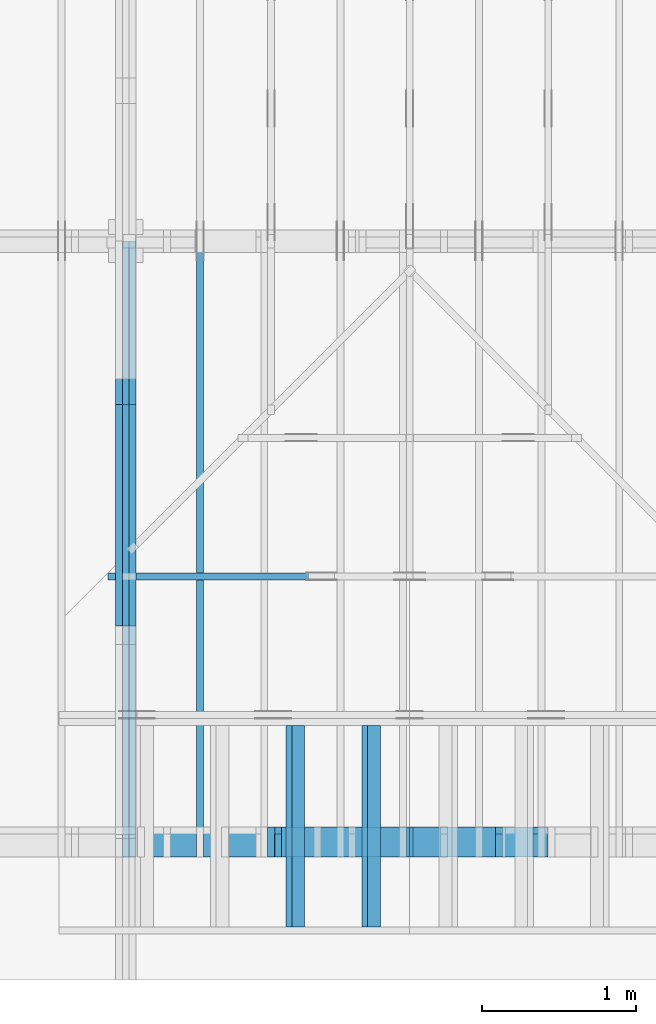
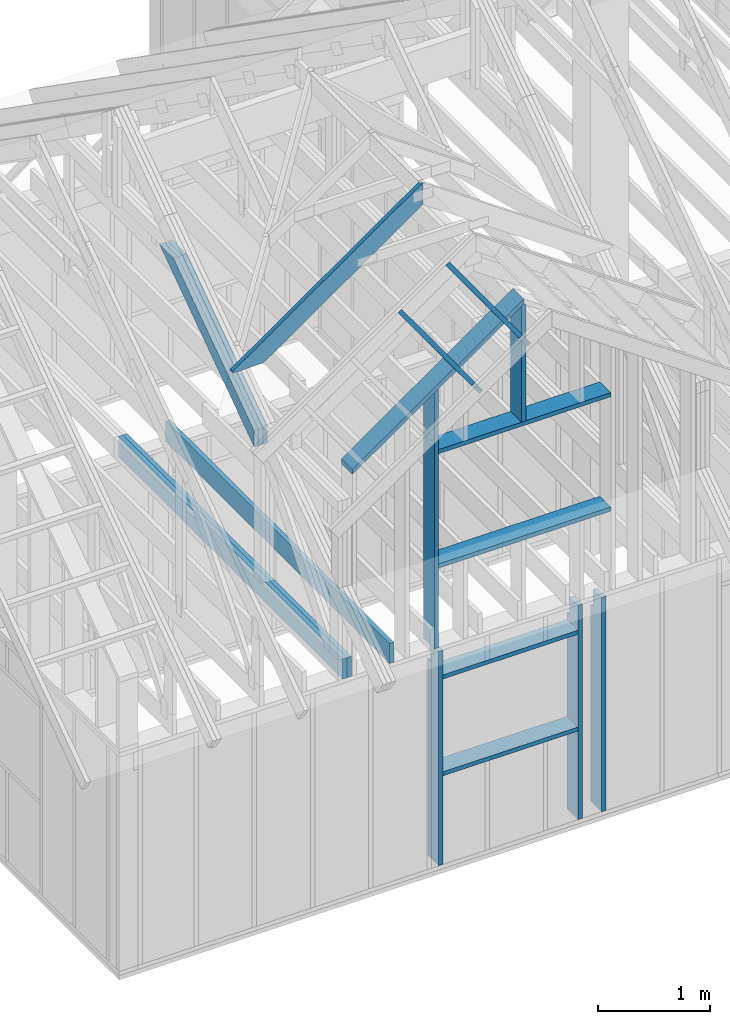
# One storey, part 6 of 70: 19 members, 6 elements without a shape of their own.
"""IFC2X3 building model written with IfcOpenShell, lengths in millimetres."""

from ifc_helpers import new_model, si_unit, frame, origin, origin_with_axes, origin_2d, place, context, project, spatial, faceted_brep, element, aggregate, save


model = new_model("IFC2X3")

# Units and contexts
model_context = context("Model", 3, precision=1e-05, world=origin())
plan_context = context("Plan", 2, precision=1e-05, world=origin_2d())
ifc_project = project(units=[si_unit("LENGTHUNIT", "METRE", prefix="MILLI"), si_unit("AREAUNIT", "SQUARE_METRE"), si_unit("VOLUMEUNIT", "CUBIC_METRE"), si_unit("SOLIDANGLEUNIT", "STERADIAN"), si_unit("PLANEANGLEUNIT", "RADIAN"), si_unit("MASSUNIT", "GRAM"), si_unit("TIMEUNIT", "SECOND"), si_unit("THERMODYNAMICTEMPERATUREUNIT", "DEGREE_CELSIUS"), si_unit("LUMINOUSINTENSITYUNIT", "LUMEN")], contexts=[model_context, plan_context])

# Site, building, storey
site_placement = place(None, origin_with_axes())
site = spatial("IfcSite", under=ifc_project, at=site_placement, CompositionType="ELEMENT")
building_placement = place(site_placement, origin_with_axes())
building = spatial("IfcBuilding", under=site, at=building_placement, Name="Layout 1", CompositionType="ELEMENT")
storey_placement = place(building_placement, origin_with_axes())
storey = spatial("IfcBuildingStorey", under=building, at=storey_placement, Name="Storey 1", CompositionType="ELEMENT", Elevation=0.0)

# Assembly, members
assembly_1_placement = place(storey_placement, frame((1969.9999999999982, 8000.000000000001, 1.1021457184401395e-14), z_axis=(-1.0, 1.836909530733566e-16, 6.123031769111886e-17), x_axis=(-1.836909530733566e-16, -1.0, 0.0)))
assembly_1 = element("IfcElementAssembly", 1, at=assembly_1_placement, inside=storey, Name="T11", AssemblyPlace="FACTORY", PredefinedType="TRUSS")
member_1_placement = place(assembly_1_placement, frame((7999.999999999999, 220.0, -135.0), z_axis=(0.0, 0.0, 1.0), x_axis=(-1.0, 1.2246063538223773e-16, 0.0)))
member_1 = element("IfcMember", 2, at=member_1_placement, Name="B3", context=model_context, shape_type="Brep", body=[
    faceted_brep([(3999.9999999999995, 220.00000000000054, 45.0), (0.0, 220.00000000000054, 45.0), (0.0, 0.0, 45.0), (3999.9999999999995, 0.0, 45.0), (0.0, 220.00000000000054, 0.0), (3999.9999999999995, 220.00000000000054, 4.898425415289508e-13), (3999.9999999999995, 0.0, 4.898425415289508e-13), (0.0, 0.0, 0.0), (0.0, 0.0, 0.0), (2.755364296100349e-15, -3.3742366240998092e-31, 45.0), (2.969670408019265e-14, 220.0, 45.0), (2.69413397840923e-14, 220.0, -1.6496267940043512e-30), (3999.9999999999995, -7.347638122934263e-13, 7.805495731188194e-29), (3999.9999999999995, -7.320084479973259e-13, 45.0), (5.061354936149714e-31, 2.755364296100349e-15, 45.0), (0.0, 0.0, 0.0), (3999.9999999999995, 220.00000000000054, 0.0), (3999.9999999999995, 220.00000000000054, 45.0), (3999.9999999999995, 5.400124791776761e-13, 45.0), (3999.9999999999995, 5.400124791776761e-13, 0.0), (0.0, 220.0, 0.0), (0.0, 220.0, 45.0), (3999.9999999999995, 220.00000000000065, 45.0), (3999.9999999999995, 220.00000000000065, 6.310887241768095e-30)], [[[0, 1, 2, 3]], [[4, 5, 6, 7]], [[8, 9, 10, 11]], [[12, 13, 14, 15]], [[16, 17, 18, 19]], [[20, 21, 22, 23]]]),
])
member_2_placement = place(assembly_1_placement, frame((7999.999999999999, 220.0, -180.0), z_axis=(0.0, 0.0, 1.0), x_axis=(-1.0, 1.2246063538223773e-16, 0.0)))
member_2 = element("IfcMember", 3, at=member_2_placement, Name="B3", context=model_context, shape_type="Brep", body=[
    faceted_brep([(3999.9999999999995, 220.00000000000054, 45.0), (0.0, 220.00000000000054, 45.0), (0.0, 0.0, 45.0), (3999.9999999999995, 0.0, 45.0), (0.0, 220.00000000000054, 0.0), (3999.9999999999995, 220.00000000000054, 4.898425415289508e-13), (3999.9999999999995, 0.0, 4.898425415289508e-13), (0.0, 0.0, 0.0), (0.0, 0.0, 0.0), (2.755364296100349e-15, -3.3742366240998092e-31, 45.0), (2.969670408019265e-14, 220.0, 45.0), (2.69413397840923e-14, 220.0, -1.6496267940043512e-30), (3999.9999999999995, -7.347638122934263e-13, 7.805495731188194e-29), (3999.9999999999995, -7.320084479973259e-13, 45.0), (5.061354936149714e-31, 2.755364296100349e-15, 45.0), (0.0, 0.0, 0.0), (3999.9999999999995, 220.00000000000054, 0.0), (3999.9999999999995, 220.00000000000054, 45.0), (3999.9999999999995, 5.400124791776761e-13, 45.0), (3999.9999999999995, 5.400124791776761e-13, 0.0), (0.0, 220.0, 0.0), (0.0, 220.0, 45.0), (3999.9999999999995, 220.00000000000065, 45.0), (3999.9999999999995, 220.00000000000065, 6.310887241768095e-30)], [[[0, 1, 2, 3]], [[4, 5, 6, 7]], [[8, 9, 10, 11]], [[12, 13, 14, 15]], [[16, 17, 18, 19]], [[20, 21, 22, 23]]]),
])
member_3_placement = place(assembly_1_placement, frame((6583.168583266467, 1754.0249935609681, -90.0), z_axis=(0.0, 0.0, 1.0), x_axis=(-0.8191520442887741, 0.573576436351357, 0.0)))
member_3 = element("IfcMember", 4, at=member_3_placement, Name="SC5", context=model_context, shape_type="Brep", body=[
    faceted_brep([(2065.5521701629054, 145.00000000003, 45.0), (0.0, 145.00000000003, 45.0), (101.53009304118586, 0.0, 45.0), (1858.4707091852106, 0.0, 45.0), (0.0, 145.00000000003, 0.0), (2065.5521701629054, 145.00000000003, 2.529488311733094e-13), (1858.4707091852106, 0.0, 2.275895038860988e-13), (101.53009304118586, 0.0, 1.2433439704241334e-14), (101.53009304118586, 0.0, 4.2995835069684415e-31), (101.53009304118586, 0.0, 45.0), (2.842170943040401e-14, 145.0000000000155, 45.0), (2.842170943040401e-14, 145.0000000000155, -2.4234235555743734e-30), (1858.4707091852106, 2.77410857254784e-11, 2.7752643298715197e-29), (1858.4707091852106, 2.77438410897745e-11, 45.0), (101.53009304118586, -2.2006133120472472e-14, 45.0), (101.53009304118586, -2.476149741657282e-14, 1.5161543533245607e-30), (2065.5521701629054, 145.0000000000299, 1.0940328964451725e-29), (2065.5521701629054, 145.0000000000299, 45.0), (1858.4707091852106, 2.808064891723916e-11, 45.0), (1858.4707091852106, 2.808064891723916e-11, 9.382329999429724e-30), (0.0, 145.00000000001546, 0.0), (0.0, 145.00000000001546, 45.0), (2065.5521701629054, 145.00000000003047, 45.0), (2065.5521701629054, 145.00000000003047, 2.68212707775144e-29)], [[[0, 1, 2, 3]], [[4, 5, 6, 7]], [[8, 9, 10, 11]], [[12, 13, 14, 15]], [[16, 17, 18, 19]], [[20, 21, 22, 23]]]),
])
member_4_placement = place(assembly_1_placement, frame((6583.168583266467, 1754.0249935609681, -135.0), z_axis=(0.0, 0.0, 1.0), x_axis=(-0.8191520442887741, 0.573576436351357, 0.0)))
member_4 = element("IfcMember", 5, at=member_4_placement, Name="SC5", context=model_context, shape_type="Brep", body=[
    faceted_brep([(2065.5521701629054, 145.00000000003, 45.0), (0.0, 145.00000000003, 45.0), (101.53009304118586, 0.0, 45.0), (1858.4707091852106, 0.0, 45.0), (0.0, 145.00000000003, 0.0), (2065.5521701629054, 145.00000000003, 2.529488311733094e-13), (1858.4707091852106, 0.0, 2.275895038860988e-13), (101.53009304118586, 0.0, 1.2433439704241334e-14), (101.53009304118586, 0.0, 4.2995835069684415e-31), (101.53009304118586, 0.0, 45.0), (2.842170943040401e-14, 145.0000000000155, 45.0), (2.842170943040401e-14, 145.0000000000155, -2.4234235555743734e-30), (1858.4707091852106, 2.77410857254784e-11, 2.7752643298715197e-29), (1858.4707091852106, 2.77438410897745e-11, 45.0), (101.53009304118586, -2.2006133120472472e-14, 45.0), (101.53009304118586, -2.476149741657282e-14, 1.5161543533245607e-30), (2065.5521701629054, 145.0000000000299, 1.0940328964451725e-29), (2065.5521701629054, 145.0000000000299, 45.0), (1858.4707091852106, 2.808064891723916e-11, 45.0), (1858.4707091852106, 2.808064891723916e-11, 9.382329999429724e-30), (0.0, 145.00000000001546, 0.0), (0.0, 145.00000000001546, 45.0), (2065.5521701629054, 145.00000000003047, 45.0), (2065.5521701629054, 145.00000000003047, 2.68212707775144e-29)], [[[0, 1, 2, 3]], [[4, 5, 6, 7]], [[8, 9, 10, 11]], [[12, 13, 14, 15]], [[16, 17, 18, 19]], [[20, 21, 22, 23]]]),
])
member_5_placement = place(assembly_1_placement, frame((6583.168583266467, 1754.0249935609681, -180.0), z_axis=(0.0, 0.0, 1.0), x_axis=(-0.8191520442887741, 0.573576436351357, 0.0)))
member_5 = element("IfcMember", 6, at=member_5_placement, Name="SC5", context=model_context, shape_type="Brep", body=[
    faceted_brep([(2065.5521701629054, 145.00000000003, 45.0), (0.0, 145.00000000003, 45.0), (101.53009304118586, 0.0, 45.0), (1858.4707091852106, 0.0, 45.0), (0.0, 145.00000000003, 0.0), (2065.5521701629054, 145.00000000003, 2.529488311733094e-13), (1858.4707091852106, 0.0, 2.275895038860988e-13), (101.53009304118586, 0.0, 1.2433439704241334e-14), (101.53009304118586, 0.0, 4.2995835069684415e-31), (101.53009304118586, 0.0, 45.0), (2.842170943040401e-14, 145.0000000000155, 45.0), (2.842170943040401e-14, 145.0000000000155, -2.4234235555743734e-30), (1858.4707091852106, 2.77410857254784e-11, 2.7752643298715197e-29), (1858.4707091852106, 2.77438410897745e-11, 45.0), (101.53009304118586, -2.2006133120472472e-14, 45.0), (101.53009304118586, -2.476149741657282e-14, 1.5161543533245607e-30), (2065.5521701629054, 145.0000000000299, 1.0940328964451725e-29), (2065.5521701629054, 145.0000000000299, 45.0), (1858.4707091852106, 2.808064891723916e-11, 45.0), (1858.4707091852106, 2.808064891723916e-11, 9.382329999429724e-30), (0.0, 145.00000000001546, 0.0), (0.0, 145.00000000001546, 45.0), (2065.5521701629054, 145.00000000003047, 45.0), (2065.5521701629054, 145.00000000003047, 2.68212707775144e-29)], [[[0, 1, 2, 3]], [[4, 5, 6, 7]], [[8, 9, 10, 11]], [[12, 13, 14, 15]], [[16, 17, 18, 19]], [[20, 21, 22, 23]]]),
])
aggregate(assembly_1, [member_1, member_2, member_3, member_4, member_5])

# Assembly, member
assembly_2_placement = place(storey_placement, frame((2543.749999999999, 8000.000000000001, 1.3776821480501744e-15), z_axis=(-1.0, 1.836909530733566e-16, 6.123031769111886e-17), x_axis=(-1.836909530733566e-16, -1.0, 0.0)))
assembly_2 = element("IfcElementAssembly", 7, at=assembly_2_placement, inside=storey, Name="MB1", AssemblyPlace="FACTORY", PredefinedType="TRUSS")
member_6_placement = place(assembly_2_placement, frame((8000.000000000001, 220.0, -45.0), z_axis=(0.0, 0.0, 1.0), x_axis=(-1.0, 1.2246063538223773e-16, 0.0)))
member_6 = element("IfcMember", 8, at=member_6_placement, Name="B3", context=model_context, shape_type="Brep", body=[
    faceted_brep([(4000.0000000000005, 220.0000000000005, 45.0), (0.0, 220.0000000000005, 45.0), (0.0, 0.0, 45.0), (4000.0000000000005, 0.0, 45.0), (0.0, 220.0000000000005, 0.0), (4000.0000000000005, 220.0000000000005, 4.89842541528951e-13), (4000.0000000000005, 0.0, 4.89842541528951e-13), (0.0, 0.0, 0.0), (0.0, 0.0, 0.0), (2.755364296100349e-15, -3.3742366240998092e-31, 45.0), (2.969670408019265e-14, 220.0, 45.0), (2.69413397840923e-14, 220.0, -1.6496267940043512e-30), (4000.0000000000005, -7.347638122934265e-13, 7.631468701413364e-29), (4000.0000000000005, -7.320084479973261e-13, 45.0), (5.061354936149714e-31, 2.755364296100349e-15, 45.0), (0.0, 0.0, 0.0), (4000.0000000000005, 220.0000000000005, 0.0), (4000.0000000000005, 220.0000000000005, 45.0), (4000.0000000000005, 5.115907697472721e-13, 45.0), (4000.0000000000005, 5.115907697472721e-13, 0.0), (0.0, 220.0, 0.0), (0.0, 220.0, 45.0), (4000.0000000000005, 220.00000000000065, 45.0), (4000.0000000000005, 220.00000000000065, 7.888609052210118e-30)], [[[0, 1, 2, 3]], [[4, 5, 6, 7]], [[8, 9, 10, 11]], [[12, 13, 14, 15]], [[16, 17, 18, 19]], [[20, 21, 22, 23]]]),
])
aggregate(assembly_2, [member_6])

assembly_3_placement = place(storey_placement, frame((5910.470169573801, 1845.0, 1.3776821480501744e-15), z_axis=(1.2246063538223773e-16, 1.0, 6.123031769111886e-17), x_axis=(-1.0, 1.2246063538223773e-16, 0.0)))
assembly_3 = element("IfcElementAssembly", 9, at=assembly_3_placement, inside=storey, Name="T6", AssemblyPlace="FACTORY", PredefinedType="TRUSS")
member_7_placement = place(assembly_3_placement, frame((1871.122764483497, 3504.8842505313114, -45.00000000000001), z_axis=(0.0, 0.0, 1.0), x_axis=(0.8191520442889916, -0.5735764363510465, 0.0)))
member_7 = element("IfcMember", 10, at=member_7_placement, Name="T15", context=model_context, shape_type="Brep", body=[
    faceted_brep([(2393.292165042574, 195.0000000003538, 45.0), (0.0, 195.0000000003538, 45.0), (136.54046995315502, 0.0, 45.0), (2142.2707319725655, 0.0, 45.0), (2402.328672292533, 182.09453018341355, 45.0), (0.0, 195.0000000003538, 0.0), (2393.292165042574, 195.0000000003538, 2.9308407918644497e-13), (2402.328672292533, 182.09453018341355, 2.9419069560591115e-13), (2142.2707319725655, 0.0, 2.6234383499813187e-13), (136.54046995315502, 0.0, 1.6720832705852703e-14), (136.54046995315502, 0.0, 1.2715229613070888e-30), (136.54046995315502, 0.0, 45.0), (4.263256414560601e-14, 195.0000000032287, 45.0), (4.263256414560601e-14, 195.0000000032287, -4.139884398388111e-30), (2142.2707319725655, 6.035791022220389e-10, -3.576554374768575e-29), (2142.2707319725655, 6.03581857586335e-10, 45.0), (136.54046995315502, 3.9984706098422877e-14, 45.0), (136.54046995315502, 3.722934180232253e-14, -2.279564425987233e-30), (2402.328672292534, 182.0945301834123, 7.558077827650141e-29), (2402.328672292534, 182.0945301834123, 45.0), (2142.270731972566, 6.018581188982353e-10, 45.0), (2142.270731972566, 6.018581188982353e-10, 6.491557682442349e-29), (2393.2921650425747, 195.0000000003539, 4.301139998799864e-29), (2393.2921650425747, 195.0000000003539, 45.0), (2402.3286722925336, 182.09453018341367, 45.0), (2402.3286722925336, 182.09453018341367, 1.7670755373044563e-29), (0.0, 195.0000000032287, 0.0), (0.0, 195.0000000032287, 45.0), (2393.292165042574, 195.0000000003536, 45.0), (2393.292165042574, 195.0000000003536, -1.1044052673094165e-29)], [[[0, 1, 2, 3, 4]], [[5, 6, 7, 8, 9]], [[10, 11, 12, 13]], [[14, 15, 16, 17]], [[18, 19, 20, 21]], [[22, 23, 24, 25]], [[26, 27, 28, 29]]]),
])
aggregate(assembly_3, [member_7])

# Assembly, members
assembly_4_placement = place(storey_placement, frame((-48.55339059325575, 0.0, -2470.0), z_axis=(0.0, -1.0, 6.123031769111886e-17), x_axis=(1.0, 0.0, 0.0)))
assembly_4 = element("IfcElementAssembly", 11, at=assembly_4_placement, inside=storey, Name="VE4", AssemblyPlace="FACTORY", PredefinedType="NOTDEFINED")
member_8_placement = place(assembly_4_placement, frame((4777.499999992957, 2425.0, -195.0), z_axis=(0.0, 0.0, 1.0), x_axis=(7.044874666267686e-16, -1.0, 0.0)))
member_8 = element("IfcMember", 12, at=member_8_placement, Name="S11", context=model_context, shape_type="Brep", body=[
    faceted_brep([(0.0, 45.0, 45.0), (195.00000000186265, 45.0, 45.00000000000002), (195.00000000186265, 0.0, 45.00000000000002), (0.0, 0.0, 45.0), (195.00000000186265, 9.094947017729282e-13, 0.0), (195.00000000186265, 9.094947017729282e-13, 45.0), (195.00000000186265, 45.0, 45.0), (195.00000000186265, 45.0, 0.0), (2.755364296100349e-15, -3.3742366240998092e-31, 45.0), (1.1939911949768178e-14, -1.462169203776584e-30, 195.0), (1.7450640541968876e-14, 45.0, 195.0), (8.266092888301046e-15, 45.0, 45.0), (2335.0, -4.2891837542628763e-13, 2.626280839091018e-29), (2335.0, -4.1697846347651946e-13, 195.0), (2.193253805664876e-30, 1.1939911949768178e-14, 195.0), (5.061354936149714e-31, 2.755364296100349e-15, 45.0), (195.00000000186265, -3.306437155354634e-14, 45.0), (195.00000000186265, -3.5819735849646686e-14, 2.193253805685826e-30), (-1.6871183120499046e-31, 45.0, 45.0), (-7.31084601888292e-31, 44.999999999999986, 195.0), (2335.0, 44.999999999999844, 195.0), (2335.0, 44.99999999999986, -8.67746995743113e-30), (195.00000000186265, 44.999999999999986, -7.888609052210118e-31), (195.00000000186265, 44.999999999999986, 45.0), (2335.0, 44.99999999999818, 2.842170943040401e-14), (2335.0, 44.99999999999818, 195.0), (2335.0, 1.2732925824820995e-11, 195.0), (2335.0, 1.2732925824820995e-11, 0.0), (2335.0, 44.99999999999818, 195.0), (0.0, 44.99999999999818, 195.0), (0.0, 0.0, 195.0), (2335.0, 0.0, 195.0), (195.00000000186265, 45.0, 2.3879823899764457e-14), (2335.0, 45.0, 2.859455836175251e-13), (2335.0, 1.2732925824820995e-11, 2.859455836175251e-13), (195.00000000186265, 1.2732925824820995e-11, 2.3879823899764457e-14)], [[[0, 1, 2, 3]], [[4, 5, 6, 7]], [[8, 9, 10, 11]], [[12, 13, 14, 15, 16, 17]], [[18, 19, 20, 21, 22, 23]], [[24, 25, 26, 27]], [[28, 29, 30, 31]], [[32, 33, 34, 35]]]),
])
member_9_placement = place(assembly_4_placement, frame((3099.095703128638, 2425.0, -195.0), z_axis=(0.0, 0.0, 1.0), x_axis=(-1.836909530733566e-16, -1.0, 0.0)))
member_9 = element("IfcMember", 13, at=member_9_placement, Name="S11", context=model_context, shape_type="Brep", body=[
    faceted_brep([(0.0, 45.00000000001455, 45.0), (195.00000000186265, 45.00000000001455, 45.00000000000002), (195.00000000186265, 0.0, 45.00000000000002), (0.0, 0.0, 45.0), (195.00000000186265, 1.3642420526593924e-12, 0.0), (195.00000000186265, 1.3642420526593924e-12, 45.0), (195.00000000186265, 45.000000000015916, 45.0), (195.00000000186265, 45.000000000015916, 0.0), (2.755364296100349e-15, -3.3742366240998092e-31, 45.0), (1.193991194976818e-14, -1.4621692037765842e-30, 195.00000000000003), (1.745064054197066e-14, 45.00000000001455, 195.00000000000003), (8.26609288830283e-15, 45.00000000001455, 45.0), (2335.0, -4.2891837542628763e-13, 2.626280839091018e-29), (2335.0, -4.1697846347651946e-13, 195.0), (2.193253805664876e-30, 1.1939911949768178e-14, 195.0), (5.061354936149714e-31, 2.755364296100349e-15, 45.0), (195.00000000186265, -3.306437155354634e-14, 45.0), (195.00000000186265, -3.5819735849646686e-14, 2.193253805685826e-30), (-1.6871183120499046e-31, 45.000000000015916, 45.0), (-7.31084601888292e-31, 45.0000000000159, 195.0), (2335.0, 45.00000000001576, 195.0), (2335.0, 45.000000000015774, -8.67746995743113e-30), (195.00000000186265, 45.0000000000159, -7.888609052210118e-31), (195.00000000186265, 45.0000000000159, 45.0), (2335.0, 45.00000000002956, 0.0), (2335.0, 45.00000000002956, 195.0), (2335.0, 1.5006662579253316e-11, 195.0), (2335.0, 1.5006662579253316e-11, 0.0), (2335.0, 45.00000000002956, 195.0), (0.0, 45.00000000002956, 195.0), (0.0, 0.0, 195.0), (2335.0, 0.0, 195.0), (195.00000000186265, 45.000000000015916, 2.3879823899764457e-14), (2335.0, 45.000000000015916, 2.859455836175251e-13), (2335.0, 1.5006662579253316e-11, 2.859455836175251e-13), (195.00000000186265, 1.5006662579253316e-11, 2.3879823899764457e-14)], [[[0, 1, 2, 3]], [[4, 5, 6, 7]], [[8, 9, 10, 11]], [[12, 13, 14, 15, 16, 17]], [[18, 19, 20, 21, 22, 23]], [[24, 25, 26, 27]], [[28, 29, 30, 31]], [[32, 33, 34, 35]]]),
])
member_10_placement = place(assembly_4_placement, frame((4533.899093720072, 2425.0, -195.0), z_axis=(0.0, 0.0, 1.0), x_axis=(-1.836909530733566e-16, -1.0, 0.0)))
member_10 = element("IfcMember", 14, at=member_10_placement, Name="S11", context=model_context, shape_type="Brep", body=[
    faceted_brep([(0.0, 45.00000000001455, 45.0), (195.00000000186265, 45.00000000001455, 45.00000000000002), (195.00000000186265, 1.4551915228366852e-11, 45.00000000000002), (0.0, 1.4551915228366852e-11, 45.0), (195.00000000186265, 1.3642420526593924e-11, 0.0), (195.00000000186265, 1.3642420526593924e-11, 45.0), (195.00000000186265, 45.00000000001455, 45.0), (195.00000000186265, 45.00000000001455, 0.0), (2.755364296102131e-15, 1.4551915228366852e-11, 45.0), (1.1939911949769961e-14, 1.4551915228366852e-11, 195.0), (1.745064054197066e-14, 45.00000000001455, 195.0), (8.26609288830283e-15, 45.00000000001455, 45.0), (2335.0, 1.4122996852940564e-11, 2.626280839091018e-29), (2335.0, 1.4134936764890332e-11, 195.0), (2.193253805664876e-30, 1.456385514031662e-11, 195.0), (5.061354936149714e-31, 1.4554670592662952e-11, 45.0), (195.00000000186265, 1.4518850856813305e-11, 45.0), (195.00000000186265, 1.4516095492517205e-11, 2.193253805685862e-30), (-1.6871183120499046e-31, 45.00000000001455, 45.0), (-7.31084601888292e-31, 45.00000000001454, 195.0), (2335.0, 45.000000000014396, 195.0), (2335.0, 45.00000000001441, -8.67746995743113e-30), (195.00000000186265, 45.00000000001454, -7.888609052210118e-31), (195.00000000186265, 45.00000000001454, 45.0), (2335.0, 45.00000000001455, 0.0), (2335.0, 45.00000000001455, 195.0), (2335.0, 0.0, 195.0), (2335.0, 0.0, 0.0), (2335.0, 45.00000000001455, 195.0), (0.0, 45.00000000001455, 195.0), (0.0, 1.4551915228366852e-11, 195.0), (2335.0, 1.4551915228366852e-11, 195.0), (195.00000000186265, 45.00000000001455, 2.3879823899764457e-14), (2335.0, 45.00000000001455, 2.859455836175251e-13), (2335.0, 0.0, 2.859455836175251e-13), (195.00000000186265, 0.0, 2.3879823899764457e-14)], [[[0, 1, 2, 3]], [[4, 5, 6, 7]], [[8, 9, 10, 11]], [[12, 13, 14, 15, 16, 17]], [[18, 19, 20, 21, 22, 23]], [[24, 25, 26, 27]], [[28, 29, 30, 31]], [[32, 33, 34, 35]]]),
])
member_11_placement = place(assembly_4_placement, frame((4533.899093718253, 2154.9999999987776, -195.0), z_axis=(0.0, 0.0, 1.0), x_axis=(-1.0, 1.2246063538223773e-16, 0.0)))
member_11 = element("IfcMember", 15, at=member_11_placement, Name="S21", context=model_context, shape_type="Brep", body=[
    faceted_brep([(1389.803390591435, 45.00000000001455, 195.0), (0.0, 45.00000000001455, 195.0), (0.0, 0.0, 195.0), (1389.803390591435, 0.0, 195.0), (0.0, 45.00000000001455, 0.0), (1389.803390591435, 45.00000000001455, 1.7019620626821542e-13), (1389.803390591435, 0.0, 1.7019620626821542e-13), (0.0, 0.0, 0.0), (0.0, 0.0, 0.0), (1.1939911949768178e-14, -1.462169203776584e-30, 195.0), (1.745064054197066e-14, 45.00000000001455, 195.0), (5.51072859220248e-15, 45.00000000001455, -3.3742366241009005e-31), (1389.803390591435, -2.5529430940232314e-13, 1.5631751669439038e-29), (1389.803390591435, -2.4335439745255496e-13, 195.0), (2.193253805664876e-30, 1.1939911949768178e-14, 195.0), (0.0, 0.0, 0.0), (1389.803390591435, 45.00000000001455, 0.0), (1389.803390591435, 45.00000000001455, 195.0), (1389.803390591435, 0.0, 195.0), (1389.803390591435, 0.0, 0.0), (-1.2154326714572542e-63, 45.00000000001455, 0.0), (-7.31084601888292e-31, 45.00000000001454, 195.0), (1389.803390591435, 45.00000000001445, 195.0), (1389.803390591435, 45.00000000001447, -5.127595883936577e-30)], [[[0, 1, 2, 3]], [[4, 5, 6, 7]], [[8, 9, 10, 11]], [[12, 13, 14, 15]], [[16, 17, 18, 19]], [[20, 21, 22, 23]]]),
])
member_12_placement = place(assembly_4_placement, frame((3144.095703126819, 1055.0, -195.0), z_axis=(0.0, 0.0, 1.0), x_axis=(1.0, 0.0, 0.0)))
member_12 = element("IfcMember", 16, at=member_12_placement, Name="S21", context=model_context, shape_type="Brep", body=[
    faceted_brep([(1389.8033905914344, 45.0, 195.0), (0.0, 45.0, 195.0), (0.0, 0.0, 195.0), (1389.8033905914344, 0.0, 195.0), (0.0, 45.0, 0.0), (1389.8033905914344, 45.0, 1.7019620626821537e-13), (1389.8033905914344, 0.0, 1.7019620626821537e-13), (0.0, 0.0, 0.0), (0.0, 0.0, 0.0), (1.1939911949768178e-14, -1.462169203776584e-30, 195.0), (1.7450640541968876e-14, 45.0, 195.0), (5.510728592200698e-15, 45.0, -3.3742366240998092e-31), (1389.8033905914344, -2.5529430940232304e-13, 1.5631751669439036e-29), (1389.8033905914344, -2.4335439745255486e-13, 195.0), (2.193253805664876e-30, 1.1939911949768178e-14, 195.0), (0.0, 0.0, 0.0), (1389.8033905914344, 45.0, 0.0), (1389.8033905914344, 45.0, 195.0), (1389.8033905914344, 0.0, 195.0), (1389.8033905914344, 0.0, 0.0), (0.0, 45.0, 0.0), (-7.31084601888292e-31, 44.999999999999986, 195.0), (1389.8033905914344, 44.9999999999999, 195.0), (1389.8033905914344, 44.999999999999915, -5.127595883936577e-30)], [[[0, 1, 2, 3]], [[4, 5, 6, 7]], [[8, 9, 10, 11]], [[12, 13, 14, 15]], [[16, 17, 18, 19]], [[20, 21, 22, 23]]]),
])
aggregate(assembly_4, [member_8, member_9, member_10, member_11, member_12])

assembly_5_placement = place(storey_placement, frame((5705.000000000031, 195.0, 0.0), z_axis=(1.2246063538223773e-16, 1.0, 6.123031769111886e-17), x_axis=(-1.0, 1.2246063538223773e-16, 0.0)))
assembly_5 = element("IfcElementAssembly", 17, at=assembly_5_placement, inside=storey, Name="VEg2", AssemblyPlace="FACTORY", PredefinedType="NOTDEFINED")
member_13_placement = place(assembly_5_placement, frame((1751.6890603639429, 3450.7447418030188, -195.00000000000003), z_axis=(0.0, 0.0, 1.0), x_axis=(0.8191520442889916, -0.5735764363510465, 0.0)))
member_13 = element("IfcMember", 18, at=member_13_placement, Name="P10", context=model_context, shape_type="Brep", body=[
    faceted_brep([(2157.7190856355, 45.00000000104956, 195.0), (0.0, 45.00000000104956, 195.0), (31.50933921979413, 0.0, 195.0), (2189.228424853158, 0.0, 195.0), (0.0, 45.00000000104956, 0.0), (2157.7190856355, 45.00000000104956, 2.6423565020330433e-13), (2189.228424853158, 0.0, 2.680943039043732e-13), (31.50933921979413, 0.0, 3.8586537013304516e-15), (31.50933921979414, 5.329070518200751e-15, -5.9164567891575885e-31), (31.50933921979415, 1.2434497875801753e-14, 195.0), (1.0658141036401503e-14, 45.00000000051023, 195.0), (0.0, 45.00000000051022, 3.944304526105059e-31), (2189.228424853158, 3.5890716599584927e-09, 9.87903808801862e-29), (2189.228424853158, 3.5890835998704425e-09, 195.0), (31.50933921979413, -1.1281913933684767e-14, 195.0), (31.50933921979413, -2.3221825883452946e-14, 1.4218797762120199e-30), (2157.7190856355005, 45.00000000104956, 1.262177448353619e-29), (2157.7190856355005, 45.00000000104956, 195.0), (2189.228424853158, 3.5906850825995207e-09, 195.0), (2189.228424853158, 3.5906850825995207e-09, 1.262177448353619e-29), (0.0, 45.00000000051023, 0.0), (3.2311742677852644e-27, 45.00000000051021, 195.0), (2157.7190856355, 45.00000000104956, 195.0), (2157.7190856355, 45.00000000104957, 1.1832913578315177e-30)], [[[0, 1, 2, 3]], [[4, 5, 6, 7]], [[8, 9, 10, 11]], [[12, 13, 14, 15]], [[16, 17, 18, 19]], [[20, 21, 22, 23]]]),
])
member_14_placement = place(assembly_5_placement, frame((1755.0000000018626, 3432.6717273032627, -195.0), z_axis=(0.0, 0.0, 1.0), x_axis=(-1.836909530733566e-16, -1.0, 0.0)))
member_14 = element("IfcMember", 19, at=member_14_placement, Name="S23", context=model_context, shape_type="Brep", body=[
    faceted_brep([(1277.671727304485, 44.999999999985675, 195.0), (15.754669611185363, 44.999999999985675, 195.0), (0.0, 22.49999999794818, 195.0), (15.754669608293625, 0.0, 195.0), (1277.671727304485, 0.0, 195.0), (15.754669611185363, 44.999999999985675, 1.9293268508229917e-15), (1277.671727304485, 44.999999999985675, 1.5646449153562843e-13), (1277.671727304485, 0.0, 1.5646449153562843e-13), (15.754669608293625, 0.0, 1.9293268504688677e-15), (0.0, 22.49999999794818, 0.0), (-7.105427357601002e-15, 22.49999999794819, 4.780563584468208e-31), (3.552713678800501e-15, 22.499999997948184, 195.0), (15.754669611185363, 45.000000000006374, 195.0), (15.754669611185353, 45.00000000000638, 9.990285543189555e-31), (15.754669608293625, 0.0, -9.860761315262648e-32), (15.754669608293636, 7.105427357601002e-15, 195.0), (1.7763568394002505e-14, 22.499999997948194, 195.0), (7.105427357601002e-15, 22.499999997948187, -7.888609052210118e-31), (1277.671727304485, -2.3753543190098716e-13, 2.846653234018103e-29), (1277.671727304485, -2.2559551995121898e-13, 195.0), (15.754669608293625, 6.207227076520317e-15, 195.0), (15.754669608293625, -5.7326848732478624e-15, 3.510141160120381e-31), (1277.671727304485, 44.999999999985675, 0.0), (1277.671727304485, 44.999999999985675, 195.0), (1277.671727304485, 2.2737367544323206e-13, 195.0), (1277.671727304485, 2.2737367544323206e-13, 0.0), (15.754669611185362, 45.00000000000636, 0.0), (15.754669611185362, 45.00000000000635, 195.0), (1277.671727304485, 44.99999999998554, 195.0), (1277.671727304485, 44.99999999998555, -7.494178599599612e-30)], [[[0, 1, 2, 3, 4]], [[5, 6, 7, 8, 9]], [[10, 11, 12, 13]], [[14, 15, 16, 17]], [[18, 19, 20, 21]], [[22, 23, 24, 25]], [[26, 27, 28, 29]]]),
])
member_15_placement = place(assembly_5_placement, frame((2655.0000000000005, 2818.239612523241, -195.0), z_axis=(0.0, 0.0, 1.0), x_axis=(-1.836909530733566e-16, -1.0, 0.0)))
member_15 = element("IfcMember", 20, at=member_15_placement, Name="P12", context=model_context, shape_type="Brep", body=[
    faceted_brep([(2818.239612523241, 45.0, 195.0), (31.509339219330286, 45.0, 195.0), (0.0, 2.124124875990674e-09, 195.0), (2818.239612523241, 2.124124875990674e-09, 195.0), (31.509339219330286, 45.0, 3.858653701273649e-15), (2818.239612523241, 45.0, 3.4512341360898753e-13), (2818.239612523241, 2.124124875990674e-09, 3.4512341360898753e-13), (0.0, 2.124124875990674e-09, 0.0), (1.363074572081924e-15, 2.1241239215555834e-09, -1.0188766500689454e-31), (1.1143677854274341e-14, 2.124117073103437e-09, 195.0), (31.509339219330297, 45.00000000212412, 195.0), (31.509339219330286, 45.000000002124125, 3.1142287201889547e-31), (2818.239612523241, -1.5243741034598378e-12, 9.33379106349632e-29), (2818.239612523241, -1.5124341915100697e-12, 195.0), (9.005644789463922e-27, 2.1241368159026237e-09, 195.0), (0.0, 2.124124875990674e-09, 0.0), (2818.239612523241, 45.0, 0.0), (2818.239612523241, 45.0, 195.0), (2818.239612523241, 0.0, 195.0), (2818.239612523241, 0.0, 0.0), (31.50933921933029, 45.000000002124125, 3.944304526105059e-31), (31.50933921933029, 45.00000000212412, 195.0), (2818.239612523241, 45.0000000000003, 195.0), (2818.239612523241, 45.00000000000031, 1.8932661725304283e-29)], [[[0, 1, 2, 3]], [[4, 5, 6, 7]], [[8, 9, 10, 11]], [[12, 13, 14, 15]], [[16, 17, 18, 19]], [[20, 21, 22, 23]]]),
])
member_16_placement = place(assembly_5_placement, frame((2655.000000000292, 2154.9999999987776, -195.0), z_axis=(0.0, 0.0, 1.0), x_axis=(-1.0, 1.2246063538223773e-16, 0.0)))
member_16 = element("IfcMember", 21, at=member_16_placement, Name="S11", context=model_context, shape_type="Brep", body=[
    faceted_brep([(1774.9999999999989, 45.000000000000455, 195.0), (0.0, 45.000000000000455, 195.0), (0.0, 0.0, 195.0), (1774.9999999999989, 0.0, 195.0), (0.0, 45.000000000000455, 0.0), (1774.9999999999989, 45.000000000000455, 2.173676278034718e-13), (1774.9999999999989, 0.0, 2.173676278034718e-13), (0.0, 0.0, 0.0), (0.0, 0.0, 0.0), (1.1939911949768178e-14, -1.462169203776584e-30, 195.0), (1.7450640541968876e-14, 45.0, 195.0), (5.510728592200698e-15, 45.0, -3.3742366240998092e-31), (1774.9999999999989, -3.2605144170520774e-13, 4.7808558123230095e-29), (1774.9999999999989, -3.1411152975543956e-13, 195.0), (2.193253805664876e-30, 1.1939911949768178e-14, 195.0), (0.0, 0.0, 0.0), (1774.9999999999989, 45.000000000000455, 0.0), (1774.9999999999989, 45.000000000000455, 195.0), (1774.9999999999989, 4.547473508864641e-13, 195.0), (1774.9999999999989, 4.547473508864641e-13, 0.0), (0.0, 45.0, 0.0), (1.5777218104420236e-30, 44.999999999999986, 195.0), (1774.9999999999989, 45.00000000000027, 195.0), (1774.9999999999989, 45.000000000000284, -1.064962222048366e-29)], [[[0, 1, 2, 3]], [[4, 5, 6, 7]], [[8, 9, 10, 11]], [[12, 13, 14, 15]], [[16, 17, 18, 19]], [[20, 21, 22, 23]]]),
])
member_17_placement = place(assembly_5_placement, frame((880.0000000002929, 863.1713847471983, -195.0), z_axis=(0.0, 0.0, 1.0), x_axis=(1.0, 0.0, 0.0)))
member_17 = element("IfcMember", 22, at=member_17_placement, Name="S11", context=model_context, shape_type="Brep", body=[
    faceted_brep([(1774.999999999999, 45.000000000029104, 195.0), (0.0, 45.000000000029104, 195.0), (0.0, 0.0, 195.0), (1774.999999999999, 0.0, 195.0), (0.0, 45.000000000029104, 0.0), (1774.999999999999, 45.000000000029104, 2.1736762780347186e-13), (1774.999999999999, 0.0, 2.1736762780347186e-13), (0.0, 0.0, 0.0), (0.0, 0.0, 0.0), (1.1939911949768178e-14, -1.462169203776584e-30, 195.0), (1.7450640541968876e-14, 45.0, 195.0), (5.510728592200698e-15, 45.0, -3.3742366240998092e-31), (1774.999999999999, 1.3862598813004286e-11, 4.2207063102353104e-29), (1774.999999999999, 1.3874538724954054e-11, 195.0), (-9.32496953364688e-29, 1.1939911949768178e-14, 195.0), (0.0, 0.0, 0.0), (1774.999999999999, 45.000000000029104, 0.0), (1774.999999999999, 45.000000000029104, 195.0), (1774.999999999999, 1.4551915228366852e-11, 195.0), (1774.999999999999, 1.4551915228366852e-11, 0.0), (0.0, 45.0, 0.0), (2.0194839173657902e-28, 44.999999999999986, 195.0), (1774.999999999999, 45.00000000002905, 195.0), (1774.999999999999, 45.000000000029054, -2.7610131682735413e-30)], [[[0, 1, 2, 3]], [[4, 5, 6, 7]], [[8, 9, 10, 11]], [[12, 13, 14, 15]], [[16, 17, 18, 19]], [[20, 21, 22, 23]]]),
])
aggregate(assembly_5, [member_13, member_14, member_15, member_16, member_17])

assembly_6_placement = place(storey_placement, frame((1649.9999999999977, -500.00000000000045, 2069.8962308951445), z_axis=(-0.5735764363510462, -1.1073377781974426e-17, 0.8191520442889918), x_axis=(0.8191520442889918, 3.5120267417914375e-17, 0.5735764363510462)))
assembly_6 = element("IfcElementAssembly", 23, at=assembly_6_placement, inside=storey, Name="gs6", AssemblyPlace="FACTORY", PredefinedType="TRUSS")
member_18_placement = place(assembly_6_placement, frame((1844.9999999994907, 45.0, -145.0), z_axis=(0.0, 0.0, 1.0), x_axis=(6.123031769111886e-17, 1.0, 0.0)))
member_18 = element("IfcMember", 24, at=member_18_placement, Name="W3", context=model_context, shape_type="Brep", body=[
    faceted_brep([(1310.0, 45.0, 145.0), (0.0, 45.0, 145.0), (0.0, 0.0, 145.0), (1310.0, 0.0, 145.0), (0.0, 45.0, 0.0), (1310.0, 45.0, 1.6042343235073142e-13), (1310.0, 0.0, 1.6042343235073142e-13), (0.0, 0.0, 0.0), (0.0, 0.0, 0.0), (8.878396065212235e-15, -1.0872540233210496e-30, 145.0), (1.4389124657412933e-14, 45.0, 145.0), (5.510728592200698e-15, 45.0, -3.3742366240998092e-31), (1310.0, 1.3721529609159872e-11, 5.084477527017986e-29), (1310.0, 1.3730408005225084e-11, 145.0), (-9.299631640508258e-29, 8.878396065212235e-15, 145.0), (0.0, 0.0, 0.0), (1310.0, 45.0, 0.0), (1310.0, 45.0, 145.0), (1310.0, 1.4551915228366852e-11, 145.0), (1310.0, 1.4551915228366852e-11, 0.0), (0.0, 45.0, 0.0), (-5.436270116605248e-31, 44.99999999999999, 145.0), (1310.0, 44.99999999999991, 145.0), (1310.0, 44.99999999999992, -4.733165431326071e-30)], [[[0, 1, 2, 3]], [[4, 5, 6, 7]], [[8, 9, 10, 11]], [[12, 13, 14, 15]], [[16, 17, 18, 19]], [[20, 21, 22, 23]]]),
])
member_19_placement = place(assembly_6_placement, frame((2444.9999999994907, 45.0, -145.0), z_axis=(0.0, 0.0, 1.0), x_axis=(6.123031769111886e-17, 1.0, 0.0)))
member_19 = element("IfcMember", 25, at=member_19_placement, Name="W3", context=model_context, shape_type="Brep", body=[
    faceted_brep([(1310.0000000000002, 45.0, 145.0), (0.0, 45.0, 145.0), (0.0, 0.0, 145.0), (1310.0000000000002, 0.0, 145.0), (0.0, 45.0, 0.0), (1310.0000000000002, 45.0, 1.6042343235073145e-13), (1310.0000000000002, 0.0, 1.6042343235073145e-13), (0.0, 0.0, 0.0), (0.0, 0.0, 0.0), (8.878396065212235e-15, -1.0872540233210496e-30, 145.0), (1.4389124657412933e-14, 45.0, 145.0), (5.510728592200698e-15, 45.0, -3.3742366240998092e-31), (1310.0000000000002, -2.406351485260972e-13, 1.4734166591902503e-29), (1310.0000000000002, -2.3175675246088495e-13, 145.0), (1.6308810349815745e-30, 8.878396065212235e-15, 145.0), (0.0, 0.0, 0.0), (1310.0000000000002, 45.0, 0.0), (1310.0000000000002, 45.0, 145.0), (1310.0000000000002, 0.0, 145.0), (1310.0000000000002, 0.0, 0.0), (0.0, 45.0, 0.0), (-5.436270116605248e-31, 44.99999999999999, 145.0), (1310.0000000000002, 44.99999999999991, 145.0), (1310.0000000000002, 44.99999999999992, -4.733165431326071e-30)], [[[0, 1, 2, 3]], [[4, 5, 6, 7]], [[8, 9, 10, 11]], [[12, 13, 14, 15]], [[16, 17, 18, 19]], [[20, 21, 22, 23]]]),
])
aggregate(assembly_6, [member_18, member_19])

save(model, "model.ifc")
